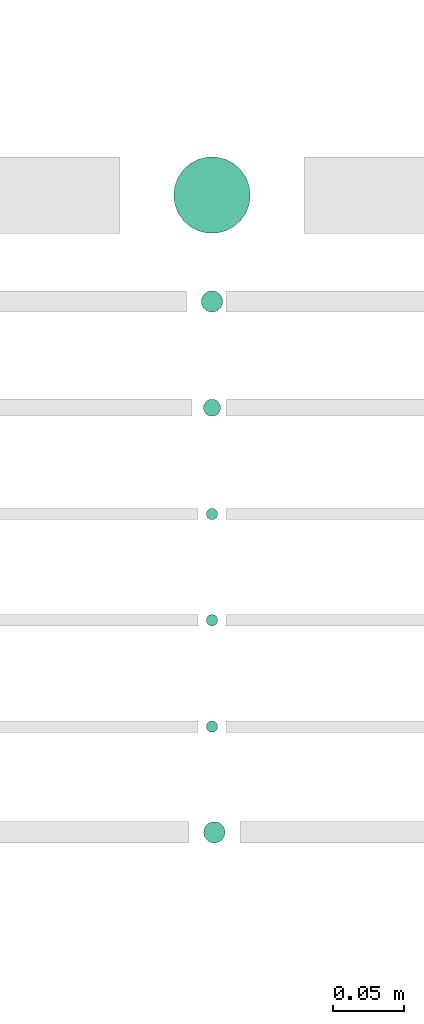
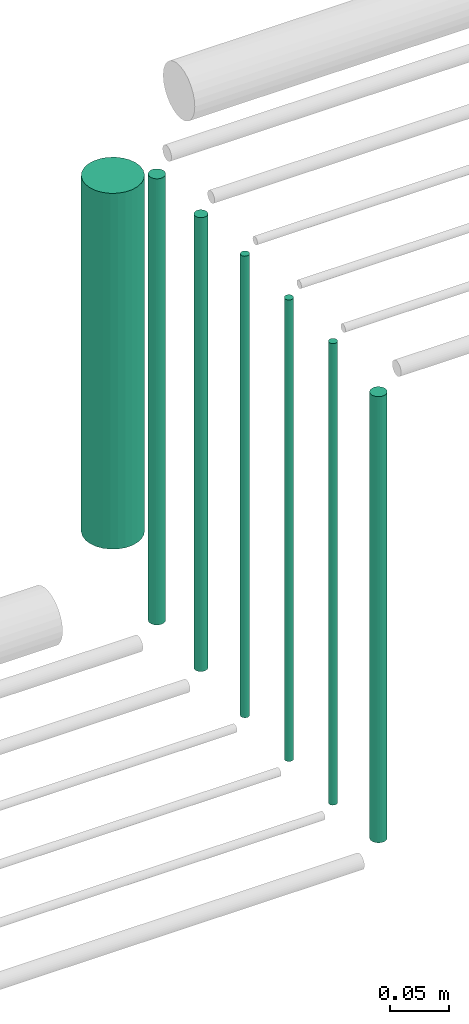
# One storey, part 46 of 65: 7 flow segments.
"""IFC2X3 building model written with IfcOpenShell, lengths in millimetres."""

from ifc_helpers import new_model, entity, si_unit, converted_unit, derived_unit, direction, frame, frame_2d, origin, origin_2d_with_axis, place, context, subcontext, project, spatial, circle, extrude, type_object, element, save


model = new_model("IFC2X3")

# Units and contexts
model_context = context("Model", 3, precision=0.01, world=origin(), true_north=direction((6.12303176911189e-17, 1.0)))
body_context = subcontext(model_context, "Body", "Model", "MODEL_VIEW")
ifc_project = project(units=[si_unit("LENGTHUNIT", "METRE", prefix="MILLI"), si_unit("AREAUNIT", "SQUARE_METRE"), si_unit("VOLUMEUNIT", "CUBIC_METRE"), converted_unit("PLANEANGLEUNIT", "DEGREE", entity("IfcRatioMeasure", 0.0174532925199433), si_unit("PLANEANGLEUNIT", "RADIAN"), dimensions=[0, 0, 0, 0, 0, 0, 0]), si_unit("MASSUNIT", "GRAM", prefix="KILO"), derived_unit("MASSDENSITYUNIT", [(si_unit("MASSUNIT", "GRAM", prefix="KILO"), 1), (si_unit("LENGTHUNIT", "METRE"), -3)]), derived_unit("MOMENTOFINERTIAUNIT", [(si_unit("LENGTHUNIT", "METRE"), 4)]), si_unit("TIMEUNIT", "SECOND"), si_unit("FREQUENCYUNIT", "HERTZ"), si_unit("THERMODYNAMICTEMPERATUREUNIT", "DEGREE_CELSIUS"), derived_unit("THERMALTRANSMITTANCEUNIT", [(si_unit("MASSUNIT", "GRAM", prefix="KILO"), 1), (si_unit("THERMODYNAMICTEMPERATUREUNIT", "KELVIN"), -1), (si_unit("TIMEUNIT", "SECOND"), -3)]), derived_unit("VOLUMETRICFLOWRATEUNIT", [(si_unit("LENGTHUNIT", "METRE"), 3), (si_unit("TIMEUNIT", "SECOND"), -1)]), derived_unit("MASSFLOWRATEUNIT", [(si_unit("MASSUNIT", "GRAM", prefix="KILO"), 1), (si_unit("TIMEUNIT", "SECOND"), -1)]), derived_unit("ROTATIONALFREQUENCYUNIT", [(si_unit("TIMEUNIT", "SECOND"), -1)]), si_unit("ELECTRICCURRENTUNIT", "AMPERE"), si_unit("ELECTRICVOLTAGEUNIT", "VOLT"), si_unit("POWERUNIT", "WATT"), si_unit("FORCEUNIT", "NEWTON", prefix="KILO"), si_unit("ILLUMINANCEUNIT", "LUX"), si_unit("LUMINOUSFLUXUNIT", "LUMEN"), si_unit("LUMINOUSINTENSITYUNIT", "CANDELA"), derived_unit("USERDEFINED", [(si_unit("MASSUNIT", "GRAM", prefix="KILO"), -1), (si_unit("LENGTHUNIT", "METRE"), -2), (si_unit("TIMEUNIT", "SECOND"), 3), (si_unit("LUMINOUSFLUXUNIT", "LUMEN"), 1)]), derived_unit("LINEARVELOCITYUNIT", [(si_unit("LENGTHUNIT", "METRE"), 1), (si_unit("TIMEUNIT", "SECOND"), -1)]), si_unit("PRESSUREUNIT", "PASCAL"), derived_unit("USERDEFINED", [(si_unit("LENGTHUNIT", "METRE"), -2), (si_unit("MASSUNIT", "GRAM", prefix="KILO"), 1), (si_unit("TIMEUNIT", "SECOND"), -2)]), derived_unit("LINEARFORCEUNIT", [(si_unit("MASSUNIT", "GRAM", prefix="KILO"), 1), (si_unit("LENGTHUNIT", "METRE"), 1), (si_unit("TIMEUNIT", "SECOND"), -2), (si_unit("LENGTHUNIT", "METRE"), -1)]), derived_unit("PLANARFORCEUNIT", [(si_unit("MASSUNIT", "GRAM", prefix="KILO"), 1), (si_unit("LENGTHUNIT", "METRE"), 1), (si_unit("TIMEUNIT", "SECOND"), -2), (si_unit("LENGTHUNIT", "METRE"), -2)])], contexts=[model_context])

# Site, building, storey
site_placement = place(None, frame((0.0, -0.00077364408347762, 0.0)))
site = spatial("IfcSite", under=ifc_project, at=site_placement, CompositionType="ELEMENT")
building_placement = place(site_placement, origin())
building = spatial("IfcBuilding", under=site, at=building_placement, CompositionType="ELEMENT")
storey_placement = place(building_placement, frame((0.0, 0.0, 19800.0)))
storey = spatial("IfcBuildingStorey", under=building, at=storey_placement, CompositionType="ELEMENT", Elevation=19800.0)

# Flow segments
pipe_segment_type = type_object("IfcPipeSegmentType", PredefinedType="NOTDEFINED")
flow_segment_1_placement = place(storey_placement, frame((69378.4358596543, 8710.77546967822, 2568.0)))
element("IfcFlowSegment", 1, at=flow_segment_1_placement, inside=storey, type_object=pipe_segment_type, context=body_context, shape_type="SweptSolid", body=[
    extrude(circle(Radius=7.5, at=origin_2d_with_axis()), frame((9.09527223591419, 9.09527223591636, 0.0), z_axis=(0.0, 0.0, 1.0), x_axis=(-1.0, 0.0, 0.0)), (0.0, 0.0, 1.0), 464.000000000011),
])
for number, where in (
    (2, (69380.2976846896, 8788.85739924042, 2560.0)),
    (3, (69380.2976846896, 8863.85739924043, 2560.0)),
    (4, (69380.2976846896, 8938.85739924043, 2560.0)),
):
    element("IfcFlowSegment", number, at=place(storey_placement, frame(where)), inside=storey, type_object=pipe_segment_type, context=body_context, shape_type="SweptSolid", body=[
        extrude(circle(Radius=4.0, at=origin_2d_with_axis()), frame((5.59527223591499, 5.59527223591607, 0.0)), (0.0, 0.0, 1.0), 480.000000000012),
    ])
flow_segment_2_placement = place(storey_placement, frame((69357.2976846896, 9140.85739924042, 2615.0)))
element("IfcFlowSegment", 5, at=flow_segment_2_placement, inside=storey, type_object=pipe_segment_type, context=body_context, shape_type="SweptSolid", body=[
    extrude(circle(Radius=27.0, at=origin_2d_with_axis()), frame((28.5952722359184, 28.5952722359163, 0.0)), (0.0, 0.0, 1.0), 370.000000000016),
])
flow_segment_3_placement = place(storey_placement, frame((69378.2976846896, 9011.85739924043, 2564.0)))
element("IfcFlowSegment", 6, at=flow_segment_3_placement, inside=storey, type_object=pipe_segment_type, context=body_context, shape_type="SweptSolid", body=[
    extrude(circle(Radius=6.0, at=origin_2d_with_axis()), frame((7.59527223591454, 7.59527223591562, 0.0)), (0.0, 0.0, 1.0), 472.000000000018),
])
flow_segment_4_placement = place(storey_placement, frame((69376.7976846896, 9085.35739924043, 2568.0)))
element("IfcFlowSegment", 7, at=flow_segment_4_placement, inside=storey, type_object=pipe_segment_type, context=body_context, shape_type="SweptSolid", body=[
    extrude(circle(Radius=7.5, at=frame_2d((-8.66293703438714e-12, 0.0), x_axis=(1.0, 0.0))), frame((9.09527223592286, 9.09527223591636, 0.0)), (0.0, 0.0, 1.0), 464.000000000011),
])

save(model, "model.ifc")
